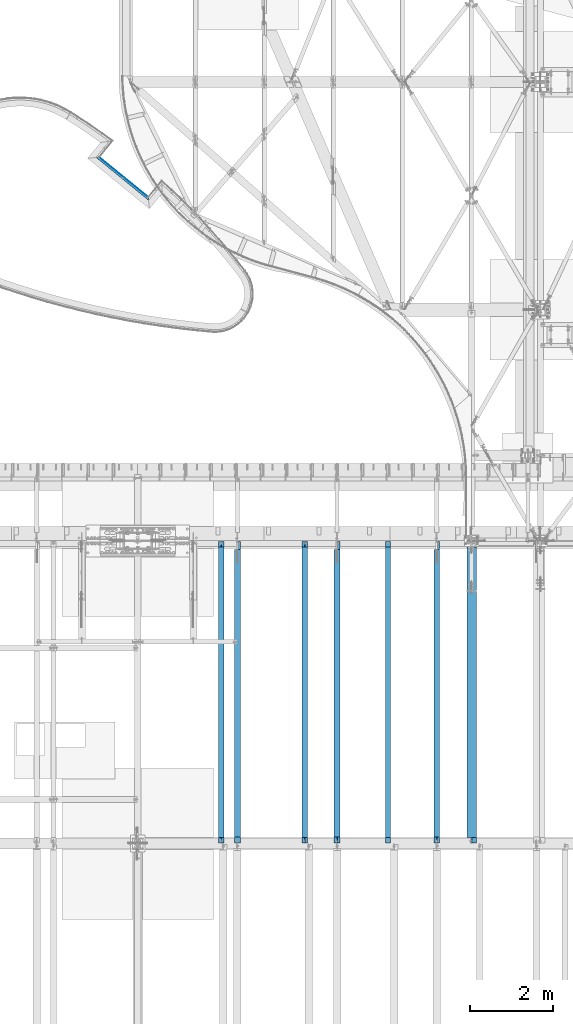
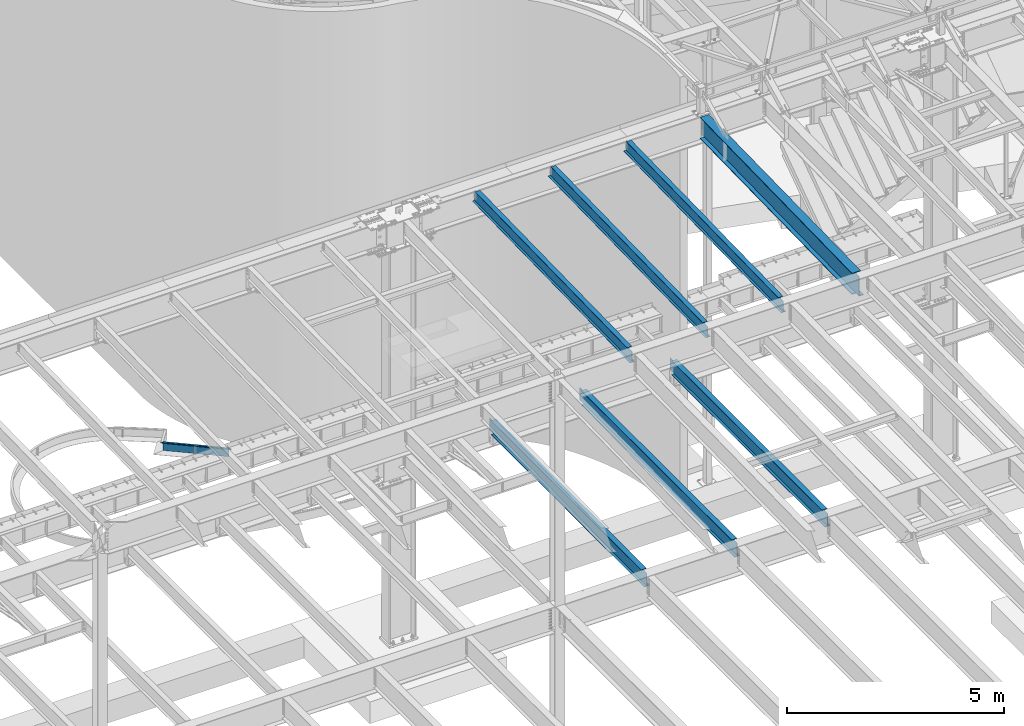
# One storey, part 1140 of 1763: 9 beams, 8 elements without a shape of their own.
"""IFC2X3 building model written with IfcOpenShell, lengths in millimetres."""

import ifcopenshell
import ifcopenshell.guid

model = None  # the IFC model being written
_history = None  # IfcOwnerHistory: only IFC2X3 demands one
_inside = {}  # id of a spatial element -> (the spatial element, [elements in it])
_under = {}  # id of a project, library or spatial element -> (it, [spatial elements below it])
_declared = {}  # id of a project -> (the project, [libraries it declares])
_typed = {}  # id of a type object -> (the type object, [elements of that type])
_made_of = {}  # id of a material, layer set ... -> (it, [elements and type objects made of it])


def new_model(schema):
    """Start an empty IFC model of exactly this schema.

    Asked for "IFC4X3", IfcOpenShell would pick the latest addendum, in which some entities
    have other attributes; the version numbers below select the first issue.
    IFC2X3 requires an IfcOwnerHistory on every rooted entity: one is made here for all.
    """
    global model, _history
    if schema == "IFC4X3":
        model = ifcopenshell.file(schema_version=(4, 3, 0, 0))
    else:
        model = ifcopenshell.file(schema=schema)
    _inside.clear()
    _under.clear()
    _declared.clear()
    _typed.clear()
    _made_of.clear()
    _history = None
    if model.schema == "IFC2X3":
        org = make("IfcOrganization", Name="unknown")
        user = make(
            "IfcPersonAndOrganization",
            ThePerson=make("IfcPerson", FamilyName="unknown"),
            TheOrganization=org,
        )
        app = make(
            "IfcApplication",
            ApplicationDeveloper=org,
            Version="unknown",
            ApplicationFullName="unknown",
            ApplicationIdentifier="unknown",
        )
        _history = make(
            "IfcOwnerHistory",
            OwningUser=user,
            OwningApplication=app,
            ChangeAction="ADDED",
            CreationDate=0,
        )
    return model


def make(cls, **values):
    """One entity of the class cls with the attributes given. An attribute that is None is left unset."""
    return model.create_entity(
        cls, **{name: value for name, value in values.items() if value is not None}
    )


def rooted(cls, **values):
    """An entity with a GlobalId (a new one), such as an element, a storey or a relation."""
    return make(cls, GlobalId=ifcopenshell.guid.new(), OwnerHistory=_history, **values)


def si_unit(unit_type, name, prefix=None):
    """IfcSIUnit, for example si_unit("LENGTHUNIT", "METRE", prefix="MILLI")."""
    return make("IfcSIUnit", UnitType=unit_type, Prefix=prefix, Name=name)


def assignment(units):
    """IfcUnitAssignment: the units of a project."""
    return None if units is None else make("IfcUnitAssignment", Units=units)


def point(xyz):
    """IfcCartesianPoint."""
    return None if xyz is None else make("IfcCartesianPoint", Coordinates=xyz)


def direction(xyz):
    """IfcDirection."""
    return None if xyz is None else make("IfcDirection", DirectionRatios=xyz)


def frame(location, z_axis=None, x_axis=None):
    """IfcAxis2Placement3D, a coordinate frame: its origin and axes. An axis left out is left unset."""
    return make(
        "IfcAxis2Placement3D",
        Location=point(location),
        Axis=direction(z_axis),
        RefDirection=direction(x_axis),
    )


def origin_with_axes():
    """The frame at (0, 0, 0) with the z axis (0, 0, 1) and the x axis (1, 0, 0) written out."""
    return frame((0.0, 0.0, 0.0), z_axis=(0.0, 0.0, 1.0), x_axis=(1.0, 0.0, 0.0))


def place(relative_to, where):
    """IfcLocalPlacement: puts the frame where relative to a parent placement (None: the world)."""
    return make(
        "IfcLocalPlacement", PlacementRelTo=relative_to, RelativePlacement=where
    )


def context(
    kind, dimensions, precision=None, world=None, true_north=None, identifier=None
):
    """IfcGeometricRepresentationContext, for example the 3D "Model" context."""
    return make(
        "IfcGeometricRepresentationContext",
        ContextIdentifier=identifier,
        ContextType=kind,
        CoordinateSpaceDimension=dimensions,
        Precision=precision,
        WorldCoordinateSystem=world,
        TrueNorth=true_north,
    )


def subcontext(parent, identifier, kind, view, scale=None):
    """IfcGeometricRepresentationSubContext, for example "Body" below "Model"."""
    return make(
        "IfcGeometricRepresentationSubContext",
        ContextIdentifier=identifier,
        ContextType=kind,
        ParentContext=parent,
        TargetScale=scale,
        TargetView=view,
    )


def project(units=None, contexts=None):
    """IfcProject with its units and contexts."""
    return rooted(
        "IfcProject",
        Name="project",
        RepresentationContexts=contexts,
        UnitsInContext=assignment(units),
    )


def spatial(cls, under=None, at=None, **own):
    """A site, building, storey or space (cls), placed at a placement, below another one or the project."""
    s = rooted(cls, ObjectPlacement=at, **own)
    if under is not None:
        _under.setdefault(under.id(), (under, []))[1].append(s)
    return s


def faces_of(points, faces, orient=None, outer=None):
    """IfcFace entities. A face is a list of loops; a loop is a list of indices into points, from 0.

    orient and outer hold one flag for each loop. By default every Orientation is true, the
    first loop of a face is its IfcFaceOuterBound and the others are IfcFaceBound.
    """
    made = []
    for i, loops in enumerate(faces):
        bounds = []
        for j, loop in enumerate(loops):
            is_outer = j == 0 if outer is None else outer[i][j]
            bounds.append(
                make(
                    "IfcFaceOuterBound" if is_outer else "IfcFaceBound",
                    Bound=make("IfcPolyLoop", Polygon=[points[k] for k in loop]),
                    Orientation=True if orient is None else orient[i][j],
                )
            )
        made.append(make("IfcFace", Bounds=bounds))
    return made


def faceted_brep(points, faces, orient=None, outer=None, voids=None):
    """IfcFacetedBrep: a solid bounded by flat faces; with voids (closed shells), ...WithVoids."""
    shared = [point(p) for p in points]
    hull = make("IfcClosedShell", CfsFaces=faces_of(shared, faces, orient, outer))
    if voids is None:
        return make("IfcFacetedBrep", Outer=hull)
    return make(
        "IfcFacetedBrepWithVoids",
        Outer=hull,
        Voids=[
            make(cls, CfsFaces=faces_of(shared, fs, o, b)) for cls, fs, o, b in voids
        ],
    )


def shape(context_of_items, identifier, shape_type, items):
    """IfcShapeRepresentation: the items that make up one representation, for example the "Body"."""
    return make(
        "IfcShapeRepresentation",
        ContextOfItems=context_of_items,
        RepresentationIdentifier=identifier,
        RepresentationType=shape_type,
        Items=items,
    )


def material(Name=None, Category=None):
    """IfcMaterial."""
    return make("IfcMaterial", Name=Name, Category=Category)


def made_of(thing, what):
    """Note that an element or type object is made of a material, layer set ...; save() writes the relation."""
    if what is not None:
        _made_of.setdefault(what.id(), (what, []))[1].append(thing)
    return thing


def type_object(cls, material=None, **own):
    """A type object (cls), such as IfcWallType, which elements share."""
    return made_of(rooted(cls, **own), material)


def element(
    cls,
    number,
    at=None,
    inside=None,
    cuts=None,
    type_object=None,
    material=None,
    context=None,
    identifier="Body",
    shape_type=None,
    held_by="IfcProductDefinitionShape",
    body=None,
    shapes=None,
    **own,
):
    """One element of the class cls, such as IfcWall. Its Tag is "e" and its number.

    at: its placement. inside: the storey or other place that contains it. cuts: it is an
    opening in that element (IfcRelVoidsElement). A single representation is given by context,
    identifier, shape_type and body (its items); several are given by shapes. held_by: the class
    of the entity that holds the representations. save() writes the other relations.
    """
    e = rooted(cls, Tag="e%d" % number, ObjectPlacement=at, **own)
    if body is not None:
        shapes = [shape(context, identifier, shape_type, body)]
    if shapes is not None:
        e.Representation = make(held_by, Representations=shapes)
    if inside is not None:
        _inside.setdefault(inside.id(), (inside, []))[1].append(e)
    if cuts is not None:
        rooted(
            "IfcRelVoidsElement", RelatingBuildingElement=cuts, RelatedOpeningElement=e
        )
    if type_object is not None:
        _typed.setdefault(type_object.id(), (type_object, []))[1].append(e)
    return made_of(e, material)


def aggregate(whole, parts):
    """IfcRelAggregates: a whole, such as a stair, and the parts it consists of."""
    return rooted("IfcRelAggregates", RelatingObject=whole, RelatedObjects=parts)


def save(model, path):
    """Write the relations noted so far, then the file.

    IfcRelAggregates (storeys below a building ...), IfcRelContainedInSpatialStructure (elements
    in a storey), IfcRelDefinesByType, IfcRelAssociatesMaterial and IfcRelDeclares: one each for
    every whole, place, type object, material and project.
    """
    for whole, parts in _under.values():
        aggregate(whole, parts)
    for where, things in _inside.values():
        rooted(
            "IfcRelContainedInSpatialStructure",
            RelatedElements=things,
            RelatingStructure=where,
        )
    for kind, things in _typed.values():
        rooted("IfcRelDefinesByType", RelatedObjects=things, RelatingType=kind)
    for what, things in _made_of.values():
        rooted("IfcRelAssociatesMaterial", RelatedObjects=things, RelatingMaterial=what)
    for by, libraries in _declared.values():
        rooted("IfcRelDeclares", RelatingContext=by, RelatedDefinitions=libraries)
    model.write(path)


model = new_model("IFC2X3")

# Units and contexts
model_context = context("Model", 3, precision=1e-05, world=origin_with_axes())
body_context = subcontext(model_context, "Body", "Model", "MODEL_VIEW")
ifc_project = project(units=[si_unit("LENGTHUNIT", "METRE", prefix="MILLI"), si_unit("AREAUNIT", "SQUARE_METRE"), si_unit("VOLUMEUNIT", "CUBIC_METRE"), si_unit("MASSUNIT", "GRAM", prefix="KILO"), si_unit("TIMEUNIT", "SECOND"), si_unit("PLANEANGLEUNIT", "RADIAN"), si_unit("SOLIDANGLEUNIT", "STERADIAN"), si_unit("THERMODYNAMICTEMPERATUREUNIT", "DEGREE_CELSIUS"), si_unit("LUMINOUSINTENSITYUNIT", "LUMEN")], contexts=[model_context])

# Site, building, storey
site_placement = place(None, origin_with_axes())
site = spatial("IfcSite", under=ifc_project, at=site_placement, CompositionType="ELEMENT")
building_placement = place(site_placement, origin_with_axes())
building = spatial("IfcBuilding", under=site, at=building_placement, Name="Undefined", CompositionType="ELEMENT")
storey_placement = place(building_placement, origin_with_axes())
storey = spatial("IfcBuildingStorey", under=building, at=storey_placement, Name="Undefined", CompositionType="ELEMENT", Elevation=0.0)

# Assembly, beams
assembly_1_placement = place(storey_placement, origin_with_axes())
assembly_1 = element("IfcElementAssembly", 1, at=assembly_1_placement, inside=storey, Name="PLATE", AssemblyPlace="NOTDEFINED", PredefinedType="RIGID_FRAME")
ifc_material_1 = material(Name="STEEL/A36")
beam_type_1 = type_object("IfcBeamType", PredefinedType="NOTDEFINED")
beam_1_placement = place(assembly_1_placement, frame((-50389.1487908977, 61434.1908160512, -130.175), z_axis=(0.0, 0.0, 1.0), x_axis=(0.774848603464803, -0.632146851379207, 0.0)))
beam_1 = element("IfcBeam", 2, at=beam_1_placement, type_object=beam_type_1, material=ifc_material_1, Name="PLATE", context=body_context, shape_type="Brep", body=[
    faceted_brep([(1599.83816589313, 3.1749999983258, -123.825), (1599.83816589313, 3.1749999983258, 123.825), (1606.19834198261, -3.17500000165819, 123.825), (1606.19834198261, -3.17500000165819, -123.825), (76.2000000278931, 3.17499999991196, 123.825), (69.8605029431055, -3.17500000006476, 123.825), (69.8605029431055, -3.17500000006476, -123.825), (76.2000000278931, 3.17499999991196, -123.825)], [[[0, 1, 2, 3]], [[2, 1, 4, 5]], [[3, 2, 5, 6]], [[0, 3, 6, 7]], [[1, 0, 7, 4]], [[6, 5, 4, 7]]]),
])
beam_type_2 = type_object("IfcBeamType", PredefinedType="NOTDEFINED")
beam_2_placement = place(assembly_1_placement, frame((-50405.2053209367, 61414.5096615059, -3.17500000000582), z_axis=(0.632146851379196, 0.774848603464812, 0.0), x_axis=(0.774848603464803, -0.632146851379207, 0.0)))
beam_2 = element("IfcBeam", 3, at=beam_2_placement, type_object=beam_type_2, material=ifc_material_1, Name="PLATE", context=body_context, shape_type="Brep", body=[
    faceted_brep([(1599.83816591519, 3.175, 28.5749999982454), (1599.83816591519, -3.175, 28.5749999982454), (1657.07975072067, -3.175, -28.5750000016251), (1657.07975072067, 3.175, -28.5750000016251), (76.1999997228595, -3.175, 28.5749999998807), (19.1445262427587, -3.175, -28.5749999999298), (19.1445262427587, 3.175, -28.5749999999298), (76.1999997228595, 3.175, 28.5749999998807)], [[[0, 1, 2, 3]], [[2, 1, 4, 5]], [[3, 2, 5, 6]], [[0, 3, 6, 7]], [[1, 0, 7, 4]], [[6, 5, 4, 7]]]),
])
aggregate(assembly_1, [beam_2, beam_1])

# Assembly, beam
assembly_2_placement = place(storey_placement, origin_with_axes())
assembly_2 = element("IfcElementAssembly", 4, at=assembly_2_placement, inside=storey, Name="BEAM", AssemblyPlace="NOTDEFINED", PredefinedType="RIGID_FRAME")
ifc_material_2 = material(Name="STEEL/A992")
beam_type_3 = type_object("IfcBeamType", Name="W16X26", PredefinedType="NOTDEFINED")
beam_3_placement = place(assembly_2_placement, frame((-42176.1372736983, 44805.6, 4994.275), z_axis=(0.0, 0.0, 1.0), x_axis=(0.0, 1.0, 0.0)))
beam_3 = element("IfcBeam", 5, at=beam_3_placement, type_object=beam_type_3, material=ifc_material_2, Name="BEAM", ObjectType="W16X26", context=body_context, shape_type="Brep", body=[
    faceted_brep([(7104.06248869727, 3.17500000000291, -190.5), (7104.06248869734, 3.17487653380522, -200.025), (7104.06247902929, 69.8499999999985, -200.025), (7104.06247902929, 69.8499999999985, -190.5), (7294.5625, 3.17500000000291, -190.5), (7294.5625, 3.17490415680368, -200.025), (159.543749432261, 3.17500000000291, 190.5), (159.543749432261, 69.8499999999985, 190.5), (7104.0625, 69.8499999999985, 190.5), (7104.0625, 3.17500000000291, 190.5), (159.543749432261, -69.8499999999985, 200.025), (159.543749432261, 69.8499999999985, 200.025), (159.543749432261, 3.17500000000291, 180.715001487732), (159.543749432261, -3.17500000000291, 180.715001487732), (159.543749432261, -3.17500000000291, 190.5), (159.543749432261, -69.8499999999985, 190.5), (158.57701950967, 3.17500000000291, 175.854921969686), (158.57701950967, -3.17500000000291, 175.854921969686), (155.824005609196, 3.17500000000291, 171.734745501532), (155.824005609196, -3.17500000000291, 171.734745501532), (151.703829141043, 3.17500000000291, 168.981731601054), (151.703829141043, -3.17500000000291, 168.981731601054), (146.843749622996, 3.17500000000291, 168.015001678466), (146.843749622996, -3.17500000000291, 168.015001678466), (19.84375, 3.17500000000291, 168.015001678466), (19.84375, -3.17500000000291, 168.015001678466), (19.84375, 3.17500000000291, -190.5), (19.84375, 69.8499999999985, -190.5), (19.84375, 69.8499999999985, -200.025), (19.84375, -69.8499999999985, -200.025), (19.84375, -69.8499999999985, -190.5), (19.84375, -3.17500000000291, -190.5), (7294.5625, -69.8499999999985, -200.025), (7294.5625, -69.8499999999985, -190.5), (7294.5625, -3.17500000000291, -190.5), (7111.90242029122, -3.17500000000291, 156.541729922587), (7107.78224382307, -3.17500000000291, 159.294743823066), (7105.02922992258, -3.17500000000291, 163.414920291219), (7104.0625, -3.17500000000291, 168.274999809265), (7104.0625, -3.17500000000291, 190.5), (7294.5625, -3.17500000000291, 155.575), (7116.76249980927, -3.17500000000291, 155.575), (7104.0625, -69.8499999999985, 190.5), (7104.0625, -69.8499999999985, 200.025), (7104.0625, 69.8499999999985, 200.025), (7104.0625, 3.17500000000291, 168.274999809265), (7105.02922992258, 3.17500000000291, 163.414920291219), (7107.78224382307, 3.17500000000291, 159.294743823066), (7111.90242029122, 3.17500000000291, 156.541729922587), (7116.76249980927, 3.17500000000291, 155.575), (7294.5625, 3.17500000000291, 155.575), (7294.5625, 3.17500000000291, -184.976846570121)], [[[0, 1, 2, 3]], [[4, 5, 1, 0]], [[6, 7, 8, 9]], [[10, 11, 7, 6, 12, 13, 14, 15]], [[13, 12, 16, 17]], [[17, 16, 18, 19]], [[19, 18, 20, 21]], [[21, 20, 22, 23]], [[23, 22, 24, 25]], [[26, 27, 28, 29, 30, 31, 25, 24]], [[30, 29, 32, 33]], [[31, 30, 33, 34]], [[35, 36, 37, 38, 39, 14, 13, 17, 19, 21, 23, 25, 31, 34, 40, 41]], [[15, 14, 39, 42]], [[10, 15, 42, 43]], [[11, 10, 43, 44]], [[7, 11, 44, 8]], [[43, 42, 39, 38, 45, 9, 8, 44]], [[37, 46, 45, 38]], [[36, 47, 46, 37]], [[35, 48, 47, 36]], [[41, 49, 48, 35]], [[40, 50, 49, 41]], [[51, 4, 0, 26, 24, 22, 20, 18, 16, 12, 6, 9, 45, 46, 47, 48, 49, 50]], [[27, 26, 0, 3]], [[28, 27, 3, 2]], [[32, 29, 28, 2, 1, 5]], [[51, 50, 40, 34, 33, 32, 5, 4]]]),
])
aggregate(assembly_2, [beam_3])

assembly_3_placement = place(storey_placement, origin_with_axes())
assembly_3 = element("IfcElementAssembly", 6, at=assembly_3_placement, inside=storey, Name="BEAM", AssemblyPlace="NOTDEFINED", PredefinedType="RIGID_FRAME")
beam_4_placement = place(assembly_3_placement, frame((-44584.903940365, 44805.6, 4994.275), z_axis=(0.0, 0.0, 1.0), x_axis=(0.0, 1.0, 0.0)))
beam_4 = element("IfcBeam", 7, at=beam_4_placement, type_object=beam_type_3, material=ifc_material_2, Name="BEAM", ObjectType="W16X26", context=body_context, shape_type="Brep", body=[
    faceted_brep([(7104.06248869727, 3.17500000000291, -190.5), (7104.06248869734, 3.17487653380522, -200.025), (7104.06247902929, 69.8499999999985, -200.025), (7104.06247902929, 69.8499999999985, -190.5), (7294.5625, 3.17500000000291, -190.5), (7294.5625, 3.17490415680368, -200.025), (159.543749432261, 3.17500000000291, 190.5), (159.543749432261, 69.8499999999985, 190.5), (7104.0625, 69.8499999999985, 190.5), (7104.0625, 3.17500000000291, 190.5), (159.543749432261, -69.8499999999985, 200.025), (159.543749432261, 69.8499999999985, 200.025), (159.543749432261, 3.17500000000291, 180.715001487732), (159.543749432261, -3.17500000000291, 180.715001487732), (159.543749432261, -3.17500000000291, 190.5), (159.543749432261, -69.8499999999985, 190.5), (158.57701950967, 3.17500000000291, 175.854921969686), (158.57701950967, -3.17500000000291, 175.854921969686), (155.824005609196, 3.17500000000291, 171.734745501532), (155.824005609196, -3.17500000000291, 171.734745501532), (151.703829141043, 3.17500000000291, 168.981731601054), (151.703829141043, -3.17500000000291, 168.981731601054), (146.843749622996, 3.17500000000291, 168.015001678466), (146.843749622996, -3.17500000000291, 168.015001678466), (19.84375, 3.17500000000291, 168.015001678466), (19.84375, -3.17500000000291, 168.015001678466), (19.84375, 3.17500000000291, -190.5), (19.84375, 69.8499999999985, -190.5), (19.84375, 69.8499999999985, -200.025), (19.84375, -69.8499999999985, -200.025), (19.84375, -69.8499999999985, -190.5), (19.84375, -3.17500000000291, -190.5), (7294.5625, -69.8499999999985, -200.025), (7294.5625, -69.8499999999985, -190.5), (7294.5625, -3.17500000000291, -190.5), (7111.90242029122, -3.17500000000291, 156.541729922587), (7107.78224382307, -3.17500000000291, 159.294743823066), (7105.02922992258, -3.17500000000291, 163.414920291219), (7104.0625, -3.17500000000291, 168.274999809265), (7104.0625, -3.17500000000291, 190.5), (7294.5625, -3.17500000000291, 155.575), (7116.76249980927, -3.17500000000291, 155.575), (7104.0625, -69.8499999999985, 190.5), (7104.0625, -69.8499999999985, 200.025), (7104.0625, 69.8499999999985, 200.025), (7104.0625, 3.17500000000291, 168.274999809265), (7105.02922992258, 3.17500000000291, 163.414920291219), (7107.78224382307, 3.17500000000291, 159.294743823066), (7111.90242029122, 3.17500000000291, 156.541729922587), (7116.76249980927, 3.17500000000291, 155.575), (7294.5625, 3.17500000000291, 155.575), (7294.5625, 3.17500000000291, -184.976846570121)], [[[0, 1, 2, 3]], [[4, 5, 1, 0]], [[6, 7, 8, 9]], [[10, 11, 7, 6, 12, 13, 14, 15]], [[13, 12, 16, 17]], [[17, 16, 18, 19]], [[19, 18, 20, 21]], [[21, 20, 22, 23]], [[23, 22, 24, 25]], [[26, 27, 28, 29, 30, 31, 25, 24]], [[30, 29, 32, 33]], [[31, 30, 33, 34]], [[35, 36, 37, 38, 39, 14, 13, 17, 19, 21, 23, 25, 31, 34, 40, 41]], [[15, 14, 39, 42]], [[10, 15, 42, 43]], [[11, 10, 43, 44]], [[7, 11, 44, 8]], [[43, 42, 39, 38, 45, 9, 8, 44]], [[37, 46, 45, 38]], [[36, 47, 46, 37]], [[35, 48, 47, 36]], [[41, 49, 48, 35]], [[40, 50, 49, 41]], [[51, 4, 0, 26, 24, 22, 20, 18, 16, 12, 6, 9, 45, 46, 47, 48, 49, 50]], [[27, 26, 0, 3]], [[28, 27, 3, 2]], [[32, 29, 28, 2, 1, 5]], [[51, 50, 40, 34, 33, 32, 5, 4]]]),
])
aggregate(assembly_3, [beam_4])

assembly_4_placement = place(storey_placement, origin_with_axes())
assembly_4 = element("IfcElementAssembly", 8, at=assembly_4_placement, inside=storey, Name="BEAM", AssemblyPlace="NOTDEFINED", PredefinedType="RIGID_FRAME")
beam_5_placement = place(assembly_4_placement, frame((-46993.6706070317, 44805.6, 4994.275), z_axis=(0.0, 0.0, 1.0), x_axis=(0.0, 1.0, 0.0)))
beam_5 = element("IfcBeam", 9, at=beam_5_placement, type_object=beam_type_3, material=ifc_material_2, Name="BEAM", ObjectType="W16X26", context=body_context, shape_type="Brep", body=[
    faceted_brep([(7104.06248869727, 3.17500000000291, -190.5), (7104.06248869734, 3.17487653380522, -200.025), (7104.06247902929, 69.8499999999985, -200.025), (7104.06247902929, 69.8499999999985, -190.5), (7294.5625, 3.17500000000291, -190.5), (7294.5625, 3.17490415680368, -200.025), (159.543749432261, 3.17500000000291, 190.5), (159.543749432261, 69.8499999999985, 190.5), (7104.0625, 69.8499999999985, 190.5), (7104.0625, 3.17500000000291, 190.5), (159.543749432261, -69.8499999999985, 200.025), (159.543749432261, 69.8499999999985, 200.025), (159.543749432261, 3.17500000000291, 180.715001487732), (159.543749432261, -3.17500000000291, 180.715001487732), (159.543749432261, -3.17500000000291, 190.5), (159.543749432261, -69.8499999999985, 190.5), (158.57701950967, 3.17500000000291, 175.854921969686), (158.57701950967, -3.17500000000291, 175.854921969686), (155.824005609196, 3.17500000000291, 171.734745501532), (155.824005609196, -3.17500000000291, 171.734745501532), (151.703829141043, 3.17500000000291, 168.981731601054), (151.703829141043, -3.17500000000291, 168.981731601054), (146.843749622996, 3.17500000000291, 168.015001678466), (146.843749622996, -3.17500000000291, 168.015001678466), (19.84375, 3.17500000000291, 168.015001678466), (19.84375, -3.17500000000291, 168.015001678466), (19.84375, 3.17500000000291, -190.5), (19.84375, 69.8499999999985, -190.5), (19.84375, 69.8499999999985, -200.025), (19.84375, -69.8499999999985, -200.025), (19.84375, -69.8499999999985, -190.5), (19.84375, -3.17500000000291, -190.5), (7294.5625, -69.8499999999985, -200.025), (7294.5625, -69.8499999999985, -190.5), (7294.5625, -3.17500000000291, -190.5), (7111.90242029122, -3.17500000000291, 156.541729922587), (7107.78224382307, -3.17500000000291, 159.294743823066), (7105.02922992258, -3.17500000000291, 163.414920291219), (7104.0625, -3.17500000000291, 168.274999809265), (7104.0625, -3.17500000000291, 190.5), (7294.5625, -3.17500000000291, 155.575), (7116.76249980927, -3.17500000000291, 155.575), (7104.0625, -69.8499999999985, 190.5), (7104.0625, -69.8499999999985, 200.025), (7104.0625, 69.8499999999985, 200.025), (7104.0625, 3.17500000000291, 168.274999809265), (7105.02922992258, 3.17500000000291, 163.414920291219), (7107.78224382307, 3.17500000000291, 159.294743823066), (7111.90242029122, 3.17500000000291, 156.541729922587), (7116.76249980927, 3.17500000000291, 155.575), (7294.5625, 3.17500000000291, 155.575), (7294.5625, 3.17500000000291, -184.976846570121)], [[[0, 1, 2, 3]], [[4, 5, 1, 0]], [[6, 7, 8, 9]], [[10, 11, 7, 6, 12, 13, 14, 15]], [[13, 12, 16, 17]], [[17, 16, 18, 19]], [[19, 18, 20, 21]], [[21, 20, 22, 23]], [[23, 22, 24, 25]], [[26, 27, 28, 29, 30, 31, 25, 24]], [[30, 29, 32, 33]], [[31, 30, 33, 34]], [[35, 36, 37, 38, 39, 14, 13, 17, 19, 21, 23, 25, 31, 34, 40, 41]], [[15, 14, 39, 42]], [[10, 15, 42, 43]], [[11, 10, 43, 44]], [[7, 11, 44, 8]], [[43, 42, 39, 38, 45, 9, 8, 44]], [[37, 46, 45, 38]], [[36, 47, 46, 37]], [[35, 48, 47, 36]], [[41, 49, 48, 35]], [[40, 50, 49, 41]], [[51, 4, 0, 26, 24, 22, 20, 18, 16, 12, 6, 9, 45, 46, 47, 48, 49, 50]], [[27, 26, 0, 3]], [[28, 27, 3, 2]], [[32, 29, 28, 2, 1, 5]], [[51, 50, 40, 34, 33, 32, 5, 4]]]),
])
aggregate(assembly_4, [beam_5])

assembly_5_placement = place(storey_placement, origin_with_axes())
assembly_5 = element("IfcElementAssembly", 10, at=assembly_5_placement, inside=storey, Name="BEAM", AssemblyPlace="NOTDEFINED", PredefinedType="RIGID_FRAME")
beam_type_4 = type_object("IfcBeamType", Name="W14X22", PredefinedType="NOTDEFINED")
beam_6_placement = place(assembly_5_placement, frame((-47386.3062102347, 44809.2121579387, 11421.5633921212), z_axis=(0.0, -0.0206852279954837, 0.999786037781472), x_axis=(0.0, 0.999786037781472, 0.0206852279954825)))
beam_6 = element("IfcBeam", 11, at=beam_6_placement, type_object=beam_type_4, material=ifc_material_2, Name="BEAM", ObjectType="W14X22", context=body_context, shape_type="Brep", body=[
    faceted_brep([(136.091146049795, -3.17500000000291, 123.565001678358), (136.091146049795, 3.17500000000291, 123.565001678358), (17.9976630864912, 3.17500000000291, 123.56500167838), (17.9976630864912, -3.17500000000291, 123.56500167838), (140.951225567893, -3.17500000000291, 124.531731600942), (140.951225567893, 3.17500000000291, 124.531731600942), (145.071402036083, -3.17500000000291, 127.284745501414), (145.071402036083, 3.17500000000291, 127.284745501414), (147.824415936586, -3.17500000000291, 131.404921969557), (147.824415936586, 3.17500000000291, 131.404921969557), (148.791145859177, -3.17500000000291, 136.265001487593), (148.791145859177, 3.17500000000291, 136.265001487593), (148.79114585917, -63.5, 174.624999999827), (148.79114585917, 63.5, 174.624999999827), (148.791145859177, 63.5, 166.687499999833), (148.791145859177, 3.17500000000291, 166.687499999833), (148.791145859177, -3.17500000000291, 166.687499999833), (148.791145859177, -63.5, 166.687499999833), (11.9924390219312, -3.17500000000291, -166.687499999878), (11.9924390219312, -63.5, -166.687499999878), (7289.06195724197, -63.5, -166.687500001812), (7289.06195724197, -3.17500000000291, -166.687500001812), (11.8282148869548, -63.5, -174.624999999871), (7288.89773310699, -63.5, -174.625000001806), (11.8282148869548, 63.5, -174.624999999871), (7288.89773310699, 63.5, -174.625000001806), (11.9924390219312, 63.5, -166.687499999878), (7289.06195724197, 63.5, -166.687500001812), (11.9924390219312, 3.17500000000291, -166.687499999878), (7289.06195724197, 3.17500000000291, -166.687500001812), (7294.93580191941, 3.17500000000291, 117.21499785159), (7294.93580191941, -3.17500000000291, 117.21499785159), (7178.21066392501, 3.17500000000291, 117.214997851612), (7178.21066392501, -3.17500000000291, 117.214997851612), (7173.35058440694, 3.17500000000291, 118.181727774199), (7173.35058440694, -3.17500000000291, 118.181727774199), (7169.23040793875, 3.17500000000291, 120.934741674671), (7169.23040793875, -3.17500000000291, 120.934741674671), (7166.47739403824, 3.17500000000291, 125.054918142816), (7166.47739403824, -3.17500000000291, 125.054918142816), (7165.51066411565, 3.17500000000291, 129.91499766085), (7165.51066411565, -3.17500000000291, 129.91499766085), (7165.51066411565, -63.5, 174.624999997965), (7165.51066411565, -63.5, 166.68749999797), (7165.51066411565, -3.17500000000291, 166.68749999797), (7165.51066411565, 3.17500000000291, 166.68749999797), (7165.51066411565, 63.5, 166.68749999797), (7165.51066411565, 63.5, 174.624999997965)], [[[0, 1, 2, 3]], [[4, 5, 1, 0]], [[6, 7, 5, 4]], [[8, 9, 7, 6]], [[10, 11, 9, 8]], [[12, 13, 14, 15, 11, 10, 16, 17]], [[18, 19, 20, 21]], [[19, 22, 23, 20]], [[22, 24, 25, 23]], [[24, 26, 27, 25]], [[26, 28, 29, 27]], [[21, 20, 23, 25, 27, 29, 30, 31]], [[31, 30, 32, 33]], [[33, 32, 34, 35]], [[35, 34, 36, 37]], [[37, 36, 38, 39]], [[39, 38, 40, 41]], [[42, 43, 44, 41, 40, 45, 46, 47]], [[43, 42, 12, 17]], [[44, 43, 17, 16]], [[8, 6, 4, 0, 3, 18, 21, 31, 33, 35, 37, 39, 41, 44, 16, 10]], [[28, 26, 24, 22, 19, 18, 3, 2]], [[45, 40, 38, 36, 34, 32, 30, 29, 28, 2, 1, 5, 7, 9, 11, 15]], [[46, 45, 15, 14]], [[47, 46, 14, 13]], [[42, 47, 13, 12]]]),
])
aggregate(assembly_5, [beam_6])

assembly_6_placement = place(storey_placement, origin_with_axes())
assembly_6 = element("IfcElementAssembly", 12, at=assembly_6_placement, inside=storey, Name="BEAM", AssemblyPlace="NOTDEFINED", PredefinedType="RIGID_FRAME")
beam_7_placement = place(assembly_6_placement, frame((-43354.0440833075, 44809.2121579387, 11421.5633921212), z_axis=(0.0, -0.0206852279954837, 0.999786037781472), x_axis=(0.0, 0.999786037781472, 0.0206852279954825)))
beam_7 = element("IfcBeam", 13, at=beam_7_placement, type_object=beam_type_4, material=ifc_material_2, Name="BEAM", ObjectType="W14X22", context=body_context, shape_type="Brep", body=[
    faceted_brep([(136.091146049795, -3.17500000000291, 123.565001678358), (136.091146049795, 3.17500000000291, 123.565001678358), (17.9976630864912, 3.17500000000291, 123.56500167838), (17.9976630864912, -3.17500000000291, 123.56500167838), (140.951225567893, -3.17500000000291, 124.531731600942), (140.951225567893, 3.17500000000291, 124.531731600942), (145.071402036083, -3.17500000000291, 127.284745501414), (145.071402036083, 3.17500000000291, 127.284745501414), (147.824415936586, -3.17500000000291, 131.404921969557), (147.824415936586, 3.17500000000291, 131.404921969557), (148.791145859177, -3.17500000000291, 136.265001487593), (148.791145859177, 3.17500000000291, 136.265001487593), (148.79114585917, -63.5, 174.624999999827), (148.79114585917, 63.5, 174.624999999827), (148.791145859177, 63.5, 166.687499999833), (148.791145859177, 3.17500000000291, 166.687499999833), (148.791145859177, -3.17500000000291, 166.687499999833), (148.791145859177, -63.5, 166.687499999833), (11.9924390219312, -3.17500000000291, -166.687499999878), (11.9924390219312, -63.5, -166.687499999878), (7289.06195724197, -63.5, -166.687500001812), (7289.06195724197, -3.17500000000291, -166.687500001812), (11.8282148869548, -63.5, -174.624999999871), (7288.89773310699, -63.5, -174.625000001806), (11.8282148869548, 63.5, -174.624999999871), (7288.89773310699, 63.5, -174.625000001806), (11.9924390219312, 63.5, -166.687499999878), (7289.06195724197, 63.5, -166.687500001812), (11.9924390219312, 3.17500000000291, -166.687499999878), (7289.06195724197, 3.17500000000291, -166.687500001812), (7294.93580191941, 3.17500000000291, 117.21499785159), (7294.93580191941, -3.17500000000291, 117.21499785159), (7178.21066392501, 3.17500000000291, 117.214997851612), (7178.21066392501, -3.17500000000291, 117.214997851612), (7173.35058440694, 3.17500000000291, 118.181727774199), (7173.35058440694, -3.17500000000291, 118.181727774199), (7169.23040793875, 3.17500000000291, 120.934741674671), (7169.23040793875, -3.17500000000291, 120.934741674671), (7166.47739403824, 3.17500000000291, 125.054918142816), (7166.47739403824, -3.17500000000291, 125.054918142816), (7165.51066411565, 3.17500000000291, 129.91499766085), (7165.51066411565, -3.17500000000291, 129.91499766085), (7165.51066411565, -63.5, 174.624999997965), (7165.51066411565, -63.5, 166.68749999797), (7165.51066411565, -3.17500000000291, 166.68749999797), (7165.51066411565, 3.17500000000291, 166.68749999797), (7165.51066411565, 63.5, 166.68749999797), (7165.51066411565, 63.5, 174.624999997965)], [[[0, 1, 2, 3]], [[4, 5, 1, 0]], [[6, 7, 5, 4]], [[8, 9, 7, 6]], [[10, 11, 9, 8]], [[12, 13, 14, 15, 11, 10, 16, 17]], [[18, 19, 20, 21]], [[19, 22, 23, 20]], [[22, 24, 25, 23]], [[24, 26, 27, 25]], [[26, 28, 29, 27]], [[21, 20, 23, 25, 27, 29, 30, 31]], [[31, 30, 32, 33]], [[33, 32, 34, 35]], [[35, 34, 36, 37]], [[37, 36, 38, 39]], [[39, 38, 40, 41]], [[42, 43, 44, 41, 40, 45, 46, 47]], [[43, 42, 12, 17]], [[44, 43, 17, 16]], [[8, 6, 4, 0, 3, 18, 21, 31, 33, 35, 37, 39, 41, 44, 16, 10]], [[28, 26, 24, 22, 19, 18, 3, 2]], [[45, 40, 38, 36, 34, 32, 30, 29, 28, 2, 1, 5, 7, 9, 11, 15]], [[46, 45, 15, 14]], [[47, 46, 14, 13]], [[42, 47, 13, 12]]]),
])
aggregate(assembly_6, [beam_7])

assembly_7_placement = place(storey_placement, origin_with_axes())
assembly_7 = element("IfcElementAssembly", 14, at=assembly_7_placement, inside=storey, Name="BEAM", AssemblyPlace="NOTDEFINED", PredefinedType="RIGID_FRAME")
beam_8_placement = place(assembly_7_placement, frame((-45370.1751467711, 44809.2121579387, 11421.5633921212), z_axis=(0.0, -0.0206852279954837, 0.999786037781472), x_axis=(0.0, 0.999786037781472, 0.0206852279954825)))
beam_8 = element("IfcBeam", 15, at=beam_8_placement, type_object=beam_type_4, material=ifc_material_2, Name="BEAM", ObjectType="W14X22", context=body_context, shape_type="Brep", body=[
    faceted_brep([(136.091146049795, -3.17500000000291, 123.565001678358), (136.091146049795, 3.17500000000291, 123.565001678358), (17.9976630864912, 3.17500000000291, 123.56500167838), (17.9976630864912, -3.17500000000291, 123.56500167838), (140.951225567893, -3.17500000000291, 124.531731600942), (140.951225567893, 3.17500000000291, 124.531731600942), (145.071402036083, -3.17500000000291, 127.284745501414), (145.071402036083, 3.17500000000291, 127.284745501414), (147.824415936586, -3.17500000000291, 131.404921969557), (147.824415936586, 3.17500000000291, 131.404921969557), (148.791145859177, -3.17500000000291, 136.265001487593), (148.791145859177, 3.17500000000291, 136.265001487593), (148.79114585917, -63.5, 174.624999999827), (148.79114585917, 63.5, 174.624999999827), (148.791145859177, 63.5, 166.687499999833), (148.791145859177, 3.17500000000291, 166.687499999833), (148.791145859177, -3.17500000000291, 166.687499999833), (148.791145859177, -63.5, 166.687499999833), (11.9924390219312, -3.17500000000291, -166.687499999878), (11.9924390219312, -63.5, -166.687499999878), (7289.06195724197, -63.5, -166.687500001812), (7289.06195724197, -3.17500000000291, -166.687500001812), (11.8282148869548, -63.5, -174.624999999871), (7288.89773310699, -63.5, -174.625000001806), (11.8282148869548, 63.5, -174.624999999871), (7288.89773310699, 63.5, -174.625000001806), (11.9924390219312, 63.5, -166.687499999878), (7289.06195724197, 63.5, -166.687500001812), (11.9924390219312, 3.17500000000291, -166.687499999878), (7289.06195724197, 3.17500000000291, -166.687500001812), (7294.93580191941, 3.17500000000291, 117.21499785159), (7294.93580191941, -3.17500000000291, 117.21499785159), (7178.21066392501, 3.17500000000291, 117.214997851612), (7178.21066392501, -3.17500000000291, 117.214997851612), (7173.35058440694, 3.17500000000291, 118.181727774199), (7173.35058440694, -3.17500000000291, 118.181727774199), (7169.23040793875, 3.17500000000291, 120.934741674671), (7169.23040793875, -3.17500000000291, 120.934741674671), (7166.47739403824, 3.17500000000291, 125.054918142816), (7166.47739403824, -3.17500000000291, 125.054918142816), (7165.51066411565, 3.17500000000291, 129.91499766085), (7165.51066411565, -3.17500000000291, 129.91499766085), (7165.51066411565, -63.5, 174.624999997965), (7165.51066411565, -63.5, 166.68749999797), (7165.51066411565, -3.17500000000291, 166.68749999797), (7165.51066411565, 3.17500000000291, 166.68749999797), (7165.51066411565, 63.5, 166.68749999797), (7165.51066411565, 63.5, 174.624999997965)], [[[0, 1, 2, 3]], [[4, 5, 1, 0]], [[6, 7, 5, 4]], [[8, 9, 7, 6]], [[10, 11, 9, 8]], [[12, 13, 14, 15, 11, 10, 16, 17]], [[18, 19, 20, 21]], [[19, 22, 23, 20]], [[22, 24, 25, 23]], [[24, 26, 27, 25]], [[26, 28, 29, 27]], [[21, 20, 23, 25, 27, 29, 30, 31]], [[31, 30, 32, 33]], [[33, 32, 34, 35]], [[35, 34, 36, 37]], [[37, 36, 38, 39]], [[39, 38, 40, 41]], [[42, 43, 44, 41, 40, 45, 46, 47]], [[43, 42, 12, 17]], [[44, 43, 17, 16]], [[8, 6, 4, 0, 3, 18, 21, 31, 33, 35, 37, 39, 41, 44, 16, 10]], [[28, 26, 24, 22, 19, 18, 3, 2]], [[45, 40, 38, 36, 34, 32, 30, 29, 28, 2, 1, 5, 7, 9, 11, 15]], [[46, 45, 15, 14]], [[47, 46, 14, 13]], [[42, 47, 13, 12]]]),
])
aggregate(assembly_7, [beam_8])

assembly_8_placement = place(storey_placement, origin_with_axes())
assembly_8 = element("IfcElementAssembly", 16, at=assembly_8_placement, inside=storey, Name="BEAM", AssemblyPlace="NOTDEFINED", PredefinedType="RIGID_FRAME")
beam_type_5 = type_object("IfcBeamType", Name="W24X76", PredefinedType="NOTDEFINED")
beam_9_placement = place(assembly_8_placement, frame((-41337.9130198439, 44811.8720196936, 11293.0034049879), z_axis=(0.0, -0.0206852279954837, 0.999786037781472), x_axis=(0.0, 0.999786037781472, 0.0206852279954825)))
beam_9 = element("IfcBeam", 17, at=beam_9_placement, type_object=beam_type_5, material=ifc_material_2, Name="BEAM", ObjectType="W24X76", context=body_context, shape_type="Brep", body=[
    faceted_brep([(7284.21661498151, -5.55625000000146, -272.291546806537), (7283.93816423076, -5.55625000000146, -285.750000001719), (7283.57687113381, -5.55575008392771, -303.212500001706), (7283.57687113381, 5.5567499160752, -303.212500001706), (7283.93816423076, 5.55625000000146, -285.750000001719), (7284.21660642342, 5.55625000000146, -272.291960447734), (7294.94118127349, 5.55625000000146, 246.062499969968), (7294.94118127349, -5.55625000000146, 246.062499969968), (7162.77356393758, 5.55625000000146, -285.750000001688), (7162.77356393769, 5.5567499160752, -303.212500001675), (7151.78667300984, 5.5567499160752, -303.212500001673), (7152.14796610679, 5.55625000000146, -285.750000001683), (146.130714898267, 5.55625000000146, 285.749999999747), (146.130714898267, 114.300000000003, 285.749999999747), (7162.7735953162, 114.300000000003, 285.749999997881), (7162.7735953162, 5.55625000000146, 285.749999997881), (6.86864603724098, 5.55625000000146, -285.749999999785), (17.9976631130121, 5.55625000000146, 252.152501678102), (133.430715088907, 5.55625000000146, 252.15250167808), (138.290794606983, 5.55625000000146, 253.119231600662), (142.410971075173, 5.55625000000146, 255.872245501134), (145.163984975676, 5.55625000000146, 259.992421969277), (146.130714898274, 5.55625000000146, 264.85250148731), (7162.7735953162, 5.55625000000146, 258.762499779228), (7163.7403252388, 5.55625000000146, 253.902420261194), (7166.49333913931, 5.55625000000146, 249.78224379305), (7170.6135156075, 5.55625000000146, 247.029229892578), (7175.47359512558, 5.55625000000146, 246.062499969988), (133.430715088907, -5.55625000000146, 252.15250167808), (17.9976631130121, -5.55625000000146, 252.152501678102), (138.290794606983, -5.55625000000146, 253.119231600662), (142.410971075173, -5.55625000000146, 255.872245501134), (145.163984975676, -5.55625000000146, 259.992421969277), (146.130714898274, -5.55625000000146, 264.85250148731), (146.130714898267, -114.300000000003, 303.212499999734), (146.130714898267, 114.300000000003, 303.212499999734), (146.130714898267, -5.55625000000146, 285.749999999747), (146.130714898267, -114.300000000003, 285.749999999747), (7162.7735953162, -5.55625000000146, 285.749999997881), (7162.7735953162, -114.300000000003, 285.749999997881), (7162.77359531621, -114.300000000003, 303.212499997868), (7162.77359531621, 114.300000000003, 303.212499997868), (7162.7735953162, -5.55625000000146, 258.762499779228), (7163.7403252388, -5.55625000000146, 253.902420261194), (7166.49333913931, -5.55625000000146, 249.78224379305), (7170.6135156075, -5.55625000000146, 247.029229892578), (7175.47359512558, -5.55625000000146, 246.062499969988), (6.86864603724098, -5.55625000000146, -285.749999999785), (7152.14796610679, -5.55625000000146, -285.750000001683), (7162.7735722307, -5.55625000000146, -285.750000001688), (6.86864603724098, -114.300000000003, -285.749999999785), (7152.14796610682, -114.300000000003, -285.750000001684), (6.50735294029437, -114.300000000003, -303.21249999977), (7151.78667300988, -114.300000000003, -303.212500001671), (7151.78667300984, -5.55575008392771, -303.212500001673), (7162.77357223082, -5.55575008392771, -303.212500001673), (6.50735294029437, 5.8565587883495, -303.21249999977), (146.130729189834, 5.85657638096018, -303.212499999809), (146.130715525491, 114.300000000003, -303.21249999981), (7151.78667300988, 114.300000000003, -303.212500001671), (146.130715525491, 114.300000000003, -285.749999999822), (7152.14796610682, 114.300000000003, -285.750000001684), (146.130729189965, 5.85592652185733, -285.749999999822), (6.86864603724098, 5.85590897472866, -285.749999999785)], [[[0, 1, 2, 3, 4, 5, 6, 7]], [[8, 4, 3, 9, 10, 11]], [[12, 13, 14, 15]], [[5, 4, 8, 11, 16, 17, 18, 19, 20, 21, 22, 12, 15, 23, 24, 25, 26, 27, 6]], [[28, 18, 17, 29]], [[30, 19, 18, 28]], [[31, 20, 19, 30]], [[32, 21, 20, 31]], [[33, 22, 21, 32]], [[34, 35, 13, 12, 22, 33, 36, 37]], [[37, 36, 38, 39]], [[34, 37, 39, 40]], [[35, 34, 40, 41]], [[13, 35, 41, 14]], [[40, 39, 38, 42, 23, 15, 14, 41]], [[43, 24, 23, 42]], [[44, 25, 24, 43]], [[45, 26, 25, 44]], [[46, 27, 26, 45]], [[7, 6, 27, 46]], [[45, 44, 43, 42, 38, 36, 33, 32, 31, 30, 28, 29, 47, 48, 49, 1, 0, 7, 46]], [[47, 50, 51, 48]], [[50, 52, 53, 51]], [[51, 53, 54, 48]], [[1, 49, 48, 54, 55, 2]], [[54, 53, 52, 56, 57, 58, 59, 10, 9, 3, 2, 55]], [[58, 60, 61, 59]], [[11, 10, 59, 61]], [[60, 62, 63, 16, 11, 61]], [[52, 50, 47, 29, 17, 16, 63, 56]], [[62, 57, 56, 63]], [[60, 58, 57, 62]]]),
])
aggregate(assembly_8, [beam_9])

save(model, "model.ifc")
